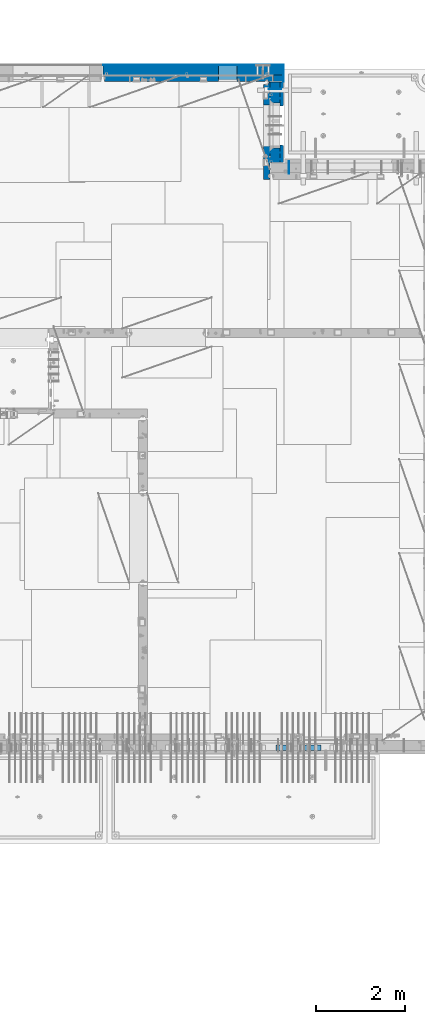
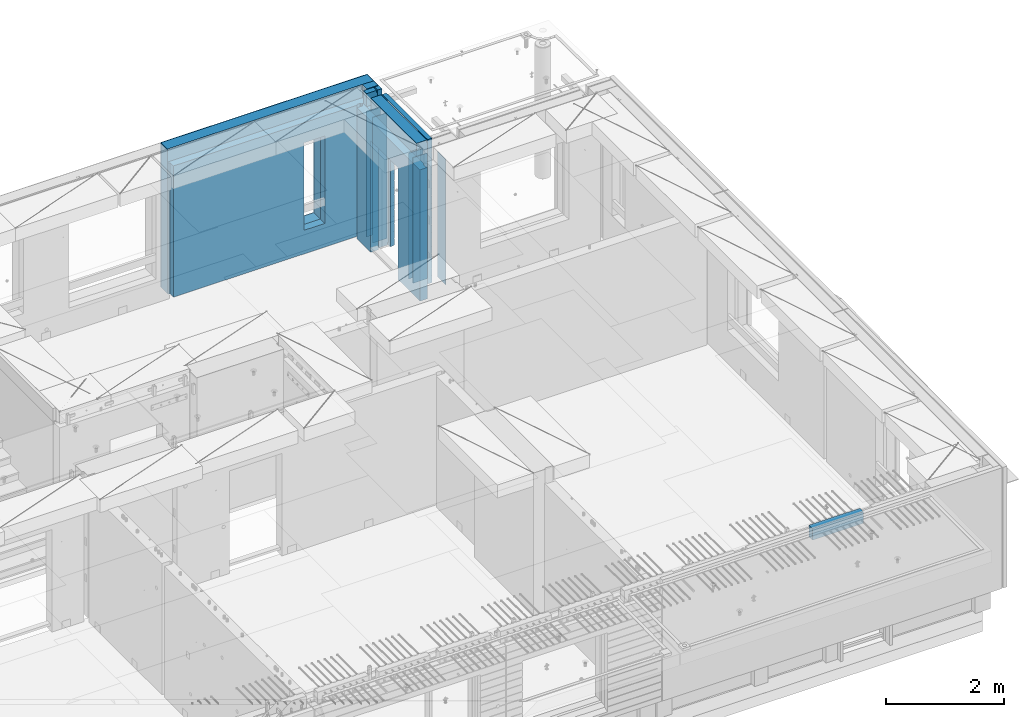
# One storey, part 220 of 325: 14 walls, 5 elements without a shape of their own.
"""IFC2X3 building model written with IfcOpenShell, lengths in millimetres."""

from ifc_helpers import new_model, si_unit, frame, origin_with_axes, place, context, subcontext, project, spatial, faceted_brep, material, type_object, element, aggregate, save


model = new_model("IFC2X3")

# Units and contexts
model_context = context("Model", 3, precision=1e-05, world=origin_with_axes())
body_context = subcontext(model_context, "Body", "Model", "MODEL_VIEW")
ifc_project = project(units=[si_unit("LENGTHUNIT", "METRE", prefix="MILLI"), si_unit("AREAUNIT", "SQUARE_METRE"), si_unit("VOLUMEUNIT", "CUBIC_METRE"), si_unit("MASSUNIT", "GRAM", prefix="KILO"), si_unit("TIMEUNIT", "SECOND"), si_unit("PLANEANGLEUNIT", "RADIAN"), si_unit("SOLIDANGLEUNIT", "STERADIAN"), si_unit("THERMODYNAMICTEMPERATUREUNIT", "DEGREE_CELSIUS"), si_unit("LUMINOUSINTENSITYUNIT", "LUMEN")], contexts=[model_context])

# Site, building, storey
site_placement = place(None, origin_with_axes())
site = spatial("IfcSite", under=ifc_project, at=site_placement, CompositionType="ELEMENT")
building_placement = place(site_placement, origin_with_axes())
building = spatial("IfcBuilding", under=site, at=building_placement, CompositionType="ELEMENT")
storey_placement = place(building_placement, origin_with_axes())
storey = spatial("IfcBuildingStorey", under=building, at=storey_placement, Name="1", CompositionType="ELEMENT", Elevation=0.0)

# Assembly, walls
assembly_1_placement = place(storey_placement, origin_with_axes())
assembly_1 = element("IfcElementAssembly", 1, at=assembly_1_placement, inside=storey, AssemblyPlace="NOTDEFINED", PredefinedType="REINFORCEMENT_UNIT")
ifc_material_1 = material(Name="Undefined")
wall_type_1 = type_object("IfcWallType", PredefinedType="NOTDEFINED")
wall_1_placement = place(assembly_1_placement, frame((31429.9951872276, 20875.0, 83115.0), z_axis=(0.0, 0.0, 1.0), x_axis=(1.0, 0.0, 0.0)))
wall_1 = element("IfcWall", 2, at=wall_1_placement, type_object=wall_type_1, material=ifc_material_1, Name="(PD)", context=body_context, shape_type="Brep", body=[
    faceted_brep([(0.0, 5.0, -1300.0), (0.0, 5.0, 1300.0), (280.0, 5.0, 1300.0), (280.0, 5.0, -1300.0), (0.0, -5.0, 1300.0), (280.0, -5.0, 1300.0), (0.0, -5.0, -1300.0), (280.0, -5.0, -1300.0)], [[[0, 1, 2, 3]], [[1, 4, 5, 2]], [[4, 6, 7, 5]], [[6, 0, 3, 7]], [[5, 7, 3, 2]], [[6, 4, 1, 0]]]),
])
wall_2_placement = place(assembly_1_placement, frame((31429.9951872276, 21025.0, 83115.0), z_axis=(0.0, 0.0, 1.0), x_axis=(1.0, 0.0, 0.0)))
wall_2 = element("IfcWall", 3, at=wall_2_placement, type_object=wall_type_1, material=ifc_material_1, Name="(PD)", context=body_context, shape_type="Brep", body=[
    faceted_brep([(0.0, 5.0, -1300.0), (0.0, 5.0, 1300.0), (280.0, 5.0, 1300.0), (280.0, 5.0, -1300.0), (0.0, -5.0, 1300.0), (280.0, -5.0, 1300.0), (0.0, -5.0, -1300.0), (280.0, -5.0, -1300.0)], [[[0, 1, 2, 3]], [[1, 4, 5, 2]], [[4, 6, 7, 5]], [[6, 0, 3, 7]], [[5, 7, 3, 2]], [[6, 4, 1, 0]]]),
])

# Assembly, wall
assembly_2_placement = place(storey_placement, origin_with_axes())
assembly_2 = element("IfcElementAssembly", 4, at=assembly_2_placement, inside=storey, AssemblyPlace="NOTDEFINED", PredefinedType="REINFORCEMENT_UNIT")
wall_3_placement = place(assembly_2_placement, frame((31890.0, 20549.9951872276, 83115.0), z_axis=(0.0, 0.0, 1.0), x_axis=(0.0, 1.0, 0.0)))
wall_3 = element("IfcWall", 5, at=wall_3_placement, type_object=wall_type_1, material=ifc_material_1, Name="(PD)", context=body_context, shape_type="Brep", body=[
    faceted_brep([(0.0, 5.0, -1300.0), (0.0, 5.0, 1300.0), (280.0, 5.0, 1300.0), (280.0, 5.0, -1300.0), (0.0, -5.0, 1300.0), (280.0, -5.0, 1300.0), (0.0, -5.0, -1300.0), (280.0, -5.0, -1300.0)], [[[0, 1, 2, 3]], [[1, 4, 5, 2]], [[4, 6, 7, 5]], [[6, 0, 3, 7]], [[5, 7, 3, 2]], [[6, 4, 1, 0]]]),
])
aggregate(assembly_2, [wall_3])

# Wall
wall_4_placement = place(assembly_1_placement, frame((31429.9951872276, 22245.0, 83115.0), z_axis=(0.0, 0.0, 1.0), x_axis=(1.0, 0.0, 0.0)))
wall_4 = element("IfcWall", 6, at=wall_4_placement, type_object=wall_type_1, material=ifc_material_1, Name="(PD)", context=body_context, shape_type="Brep", body=[
    faceted_brep([(0.0, 5.0, -1300.0), (0.0, 5.0, 1300.0), (280.0, 5.0, 1300.0), (280.0, 5.0, -1300.0), (0.0, -5.0, 1300.0), (280.0, -5.0, 1300.0), (0.0, -5.0, -1300.0), (280.0, -5.0, -1300.0)], [[[0, 1, 2, 3]], [[1, 4, 5, 2]], [[4, 6, 7, 5]], [[6, 0, 3, 7]], [[5, 7, 3, 2]], [[6, 4, 1, 0]]]),
])

wall_5_placement = place(assembly_1_placement, frame((31429.9951872276, 22454.9997558594, 83115.0), z_axis=(0.0, 0.0, 1.0), x_axis=(1.0, 0.0, 0.0)))
wall_5 = element("IfcWall", 7, at=wall_5_placement, type_object=wall_type_1, material=ifc_material_1, Name="(PD)", context=body_context, shape_type="Brep", body=[
    faceted_brep([(0.0, 5.0, -1300.0), (0.0, 5.0, 1300.0), (280.0, 5.0, 1300.0), (280.0, 5.0, -1300.0), (0.0, -5.0, 1300.0), (280.0, -5.0, 1300.0), (0.0, -5.0, -1300.0), (280.0, -5.0, -1300.0)], [[[0, 1, 2, 3]], [[1, 4, 5, 2]], [[4, 6, 7, 5]], [[6, 0, 3, 7]], [[5, 7, 3, 2]], [[6, 4, 1, 0]]]),
])

# Assemblies, wall
assembly_3_placement = place(storey_placement, origin_with_axes())
assembly_3 = element("IfcElementAssembly", 8, at=assembly_3_placement, inside=storey, AssemblyPlace="NOTDEFINED", PredefinedType="REINFORCEMENT_UNIT")
assembly_4_placement = place(assembly_3_placement, origin_with_axes())
assembly_4 = element("IfcElementAssembly", 9, at=assembly_4_placement, Name="Steel Assembly", AssemblyPlace="NOTDEFINED", PredefinedType="NOTDEFINED")
aggregate(assembly_3, [assembly_4])
ifc_material_2 = material()
wall_type_2 = type_object("IfcWallType", PredefinedType="NOTDEFINED")
wall_6_placement = place(assembly_4_placement, frame((31599.9998568133, 7690.00021946163, 84590.0), z_axis=(0.0, 0.0, 1.0), x_axis=(1.0, 0.0, 0.0)))
wall_6 = element("IfcWall", 10, at=wall_6_placement, type_object=wall_type_2, material=ifc_material_2, context=body_context, shape_type="Brep", body=[
    faceted_brep([(0.0, 60.0, -120.0), (0.0, 60.0, 120.0), (1000.0, 60.0, 120.0), (1000.0, 60.0, -120.0), (0.0, -60.0, 120.0), (1000.0, -60.0, 120.0), (0.0, -60.0, -120.0), (1000.0, -60.0, -120.0)], [[[0, 1, 2, 3]], [[1, 4, 5, 2]], [[4, 6, 7, 5]], [[6, 0, 3, 7]], [[5, 7, 3, 2]], [[6, 4, 1, 0]]]),
])
aggregate(assembly_4, [wall_6])

# Wall
ifc_material_3 = material(Name="COS5gt")
wall_type_3 = type_object("IfcWallType", PredefinedType="NOTDEFINED")
wall_7_placement = place(assembly_1_placement, frame((31569.9951872276, 22605.0, 83247.5), z_axis=(0.0, 0.0, 1.0), x_axis=(0.0, -1.0, 0.0)))
wall_7 = element("IfcWall", 11, at=wall_7_placement, type_object=wall_type_3, material=ifc_material_3, context=body_context, shape_type="Brep", body=[
    faceted_brep([(0.0, 90.0, -1492.5), (0.0, 90.0, -1442.5), (465.000109818619, 90.0, -1442.5), (465.000109818619, 90.0, -1492.5), (0.0, -110.0, -1492.5), (465.000109818619, -110.0, -1492.5), (1800.0, -110.0, 1492.5), (1800.0, 90.0, 1492.5), (255.0, 90.0, 1492.5), (255.0, -110.0, 1492.5), (1800.0, 90.0, -1442.5), (1800.0, 90.0, -1492.5), (1475.00010981862, 90.0, -1492.5), (1475.00010981862, 90.0, -1442.5), (1800.0, 110.0, -1442.5), (1475.00010981862, 110.0, -1442.5), (1800.0, 110.0, 1442.5), (1800.0, 90.0, 1442.5), (1800.0, -110.0, -1492.5), (1475.00010981862, -110.0, -1492.5), (1475.00010981862, -110.000000000004, 857.5), (1475.00010981862, 110.0, 857.5), (465.000109818619, -110.000000000004, 857.5), (465.000109818619, 110.0, 857.5), (255.0, -110.0, 1222.5), (105.0, -110.0, 1222.5), (105.0, -110.0, 1492.5), (0.0, -110.0, 1492.5), (0.0, 90.0, 1492.5), (105.0, 90.0, 1492.5), (0.0, 110.0, 1442.5), (0.0, 90.0, 1442.5), (105.0, 90.0, 1442.5), (105.0, 110.0, 1442.5), (0.0, 110.0, -1442.5), (465.000109818619, 110.0, -1442.5), (105.0, 110.0, 1222.5), (255.0, 110.0, 1222.5), (255.0, 110.0, 1442.5), (255.0, 90.0, 1442.5)], [[[0, 1, 2, 3]], [[4, 0, 3, 5]], [[6, 7, 8, 9]], [[10, 11, 12, 13]], [[14, 10, 13, 15]], [[16, 17, 7, 6, 18, 11, 10, 14]], [[11, 18, 19, 12]], [[15, 13, 12, 19, 20, 21]], [[21, 20, 22, 23]], [[19, 18, 6, 9, 24, 25, 26, 27, 4, 5, 22, 20]], [[28, 27, 26, 29]], [[30, 31, 32, 33]], [[0, 4, 27, 28, 31, 30, 34, 1]], [[1, 34, 35, 2]], [[23, 22, 5, 3, 2, 35]], [[34, 30, 33, 36, 37, 38, 16, 14, 15, 21, 23, 35]], [[17, 16, 38, 39]], [[7, 17, 39, 8]], [[38, 37, 24, 9, 8, 39]], [[36, 25, 24, 37]], [[33, 32, 29, 26, 25, 36]], [[31, 28, 29, 32]]]),
])

# Assembly, walls
assembly_5_placement = place(storey_placement, origin_with_axes())
assembly_5 = element("IfcElementAssembly", 12, at=assembly_5_placement, inside=storey, AssemblyPlace="NOTDEFINED", PredefinedType="REINFORCEMENT_UNIT")
ifc_material_4 = material()
wall_8_placement = place(assembly_5_placement, frame((31645.0, 22620.0, 83247.5), z_axis=(0.0, 0.0, 1.0), x_axis=(0.0, 1.0, 0.0)))
wall_8 = element("IfcWall", 13, at=wall_8_placement, type_object=wall_type_3, material=ifc_material_4, context=body_context, shape_type="Brep", body=[
    faceted_brep([(0.0, 110.0, -1492.5), (0.0, 110.0, 1492.5), (150.0, 110.0, 1492.5), (150.0, 110.0, -1492.5), (0.0, -110.0, 1492.5), (150.0, -110.0, 1492.5), (0.0, -110.0, -1492.5), (150.0, -110.0, -1492.5)], [[[0, 1, 2, 3]], [[1, 4, 5, 2]], [[4, 6, 7, 5]], [[6, 0, 3, 7]], [[5, 7, 3, 2]], [[6, 4, 1, 0]]]),
])
wall_9_placement = place(assembly_5_placement, frame((27720.0, 22880.0, 83247.5), z_axis=(0.0, 0.0, 1.0), x_axis=(1.0, 0.0, 0.0)))
wall_9 = element("IfcWall", 14, at=wall_9_placement, type_object=wall_type_3, material=ifc_material_4, context=body_context, shape_type="Brep", body=[
    faceted_brep([(0.0, -110.0, -1492.5), (0.0, 110.0, -1492.5), (4035.0, 110.0, -1492.5), (4035.0, -110.0, -1492.5), (0.0, -110.0, 1492.5), (0.0, 110.0, 1492.5), (4035.0, -110.0, 1492.5), (4035.0, 110.0, 1492.5), (2584.99948280293, 110.0, -1002.5), (2994.99948280293, 110.0, -1002.5), (2994.99948280293, 110.0, 807.5), (2584.99948280293, 110.0, 807.5), (2584.99948280293, -110.0, -1002.5), (2584.99948280293, -110.0, 807.5), (2994.99948280293, -110.0, 807.5), (2994.99948280293, -110.0, -1002.5)], [[[0, 1, 2, 3]], [[0, 4, 5, 1]], [[5, 4, 6, 7]], [[1, 5, 7, 2], [8, 9, 10, 11]], [[6, 3, 2, 7]], [[4, 0, 3, 6], [12, 13, 14, 15]], [[10, 14, 13, 11]], [[9, 15, 14, 10]], [[8, 12, 15, 9]], [[11, 13, 12, 8]]]),
])

# Wall
ifc_material_5 = material(Name="CONCRETE/C30/37")
wall_type_4 = type_object("IfcWallType", PredefinedType="NOTDEFINED")
wall_10_placement = place(assembly_1_placement, frame((31722.4951872276, 22605.0, 83247.5), z_axis=(0.0, 0.0, 1.0), x_axis=(0.0, -1.0, 0.0)))
wall_10 = element("IfcWall", 15, at=wall_10_placement, type_object=wall_type_4, material=ifc_material_5, context=body_context, shape_type="Brep", body=[
    faceted_brep([(0.0, 32.4999992507037, 744.999999999258), (0.0, 32.4999991127006, 755.00000040044), (526.17471776616, 32.4999991126897, 755.000000400425), (526.174717749924, 32.4999992507001, 744.999999999229), (0.0, 42.5, 742.999999944761), (524.998050995091, 42.4999995462422, 742.999999944761), (0.0, 42.5, 606.999999889245), (524.998050995091, 42.4999994639038, 606.999999889245), (3.63797880709171e-12, 32.4999991127006, 605.00000040044), (526.17471776616, 32.4999991126897, 605.000000400425), (3.63797880709171e-12, 32.4999992507037, 594.999999999258), (526.174717749924, 32.4999992507001, 594.999999999229), (0.0, 42.5, 592.999999944761), (524.998050995091, 42.4999995343132, 592.999999944761), (0.0, 42.5, 456.999999889245), (524.998050995091, 42.4999994639038, 456.999999889245), (0.0, 32.4999991127006, 455.00000040044), (526.17471776616, 32.4999991126897, 455.000000400425), (0.0, 32.4999992507037, 444.999999999258), (526.174717749924, 32.4999992507001, 444.999999999229), (0.0, 42.5, 442.999999944761), (524.998050995091, 42.4999995254038, 442.999999944761), (0.0, 42.5, 306.999999889245), (524.998050995091, 42.4999994639038, 306.999999889245), (-3.63797880709171e-12, 32.4999991127006, 305.00000040044), (526.17471776616, 32.4999991126897, 305.000000400425), (-3.63797880709171e-12, 32.4999992507037, 294.999999999258), (526.174717749924, 32.4999992507001, 294.999999999229), (0.0, 42.5, 292.999999944761), (524.998050995091, 42.499999518499, 292.999999944761), (0.0, 42.5, 156.999999889245), (524.998050995091, 42.4999994639038, 156.999999889245), (-3.63797880709171e-12, 32.4999991127006, 155.00000040044), (526.17471776616, 32.4999991126897, 155.000000400425), (-3.63797880709171e-12, 32.4999992507037, 144.999999999258), (526.174717749924, 32.4999992507001, 144.999999999229), (0.0, 42.5, 142.999999944761), (524.998050995091, 42.4999995129838, 142.999999944761), (0.0, 42.5, 6.99999988924537), (524.998050995091, 42.4999994639038, 6.99999988924537), (0.0, 32.4999991127006, 5.0000004004396), (526.17471776616, 32.4999991126897, 5.00000040042505), (0.0, 32.4999992507037, -5.00000000074215), (526.174717749924, 32.4999992507001, -5.00000000077125), (0.0, 42.5, -7.00000005523907), (524.998050995091, 42.49999950848, -7.00000005523907), (0.0, 42.5, -143.000000110755), (524.998050995091, 42.4999994639038, -143.000000110755), (3.63797880709171e-12, 32.4999991127006, -144.99999959956), (526.17471776616, 32.4999991126897, -144.999999599575), (3.63797880709171e-12, 32.4999992507037, -155.000000000742), (526.174717749924, 32.4999992507001, -155.000000000771), (0.0, 42.5, -157.000000055239), (524.998050995091, 42.4999995047365, -157.000000055239), (0.0, 42.5, -293.000000110755), (524.998050995091, 42.4999994639038, -293.000000110755), (0.0, 32.4999991127006, -294.99999959956), (526.17471776616, 32.4999991126897, -294.999999599575), (0.0, 32.4999992507037, -305.000000000742), (526.174717749924, 32.4999992507001, -305.000000000771), (0.0, 42.5, -307.000000055239), (524.998050995091, 42.4999995015714, -307.000000055239), (0.0, 42.5, -443.000000110755), (524.998050995091, 42.4999994639038, -443.000000110755), (0.0, 32.4999991127006, -444.99999959956), (526.17471776616, 32.4999991126897, -444.999999599575), (0.0, 32.4999992507037, -455.000000000742), (526.174717749924, 32.4999992507001, -455.000000000771), (0.0, 42.5, -457.000000055239), (524.998050995091, 42.4999994988648, -457.000000055239), (0.0, 42.5, -593.000000110755), (524.998050995091, 42.4999994639038, -593.000000110755), (3.63797880709171e-12, 32.4999991127006, -594.99999959956), (526.17471776616, 32.4999991126897, -594.999999599575), (3.63797880709171e-12, 32.4999992507037, -605.000000000742), (526.174717749924, 32.4999992507001, -605.000000000771), (0.0, 42.5, -607.000000055239), (524.998050995091, 42.4999994965183, -607.000000055239), (0.0, 42.5, -743.000000110755), (524.998050995091, 42.4999994639038, -743.000000110755), (0.0, 32.4999991127006, -744.99999959956), (526.17471776616, 32.4999991126897, -744.999999599575), (0.0, 32.4999992507037, -755.000000000742), (526.174717749924, 32.4999992507001, -755.000000000771), (0.0, 42.5, -757.000000055239), (524.998050995091, 42.4999994944665, -757.000000055239), (0.0, 42.5, -893.000000110755), (524.998050995091, 42.4999994639038, -893.000000110755), (0.0, 32.4999991127006, -894.99999959956), (526.17471776616, 32.4999991126897, -894.999999599575), (0.0, 32.4999992507037, -905.000000000742), (526.174717749924, 32.4999992507001, -905.000000000771), (0.0, 42.5, -907.000000055239), (524.998050995091, 42.4999994926584, -907.000000055239), (0.0, 42.5, -1043.00000011075), (524.998050995091, 42.4999994639038, -1043.00000011075), (0.0, 32.4999991127006, -1044.99999959956), (526.17471776616, 32.4999991126897, -1044.99999959957), (0.0, 32.4999992507037, -1055.00000000074), (526.174717749924, 32.4999992507001, -1055.00000000077), (0.0, 42.5, -1057.00000005524), (524.998050995091, 42.499999491054, -1057.00000005524), (0.0, 42.5, -1193.00000011075), (524.998050995091, 42.4999994639038, -1193.00000011075), (0.0, 32.4999991127006, -1194.99999959956), (526.17471776616, 32.4999991126897, -1194.99999959957), (0.0, 32.4999992507037, -1205.00000000074), (526.174717749924, 32.4999992507001, -1205.00000000077), (0.0, 42.5, -1207.00000005524), (524.998050995091, 42.499999489617, -1207.00000005524), (0.0, 42.5, -1343.00000011075), (524.998050995091, 42.4999994639038, -1343.00000011075), (0.0, 32.4999991127006, -1344.99999959956), (526.17471776616, 32.4999991126897, -1344.99999959957), (0.0, 32.4999992507037, -1355.00000000074), (526.174717749924, 32.4999992507001, -1355.00000000077), (0.0, 42.5, -1357.00000005524), (524.998050995091, 42.5, -1357.00000005524), (0.0, 42.5, -1492.5), (524.998050995091, 42.5, -1492.5), (0.0, 42.5, 1356.99999988925), (0.0, 42.5, 1492.5), (105.0, 42.5, 1492.5), (105.0, 42.499999287309, 1356.99999988925), (0.0, -42.5, 1492.5), (105.0, -42.5, 1492.5), (1800.0, 32.4999991126897, 755.000000400425), (1800.0, 32.4999992507001, 744.999999999229), (1413.82138424026, 32.4999992507001, 744.999999999229), (1413.82138422402, 32.4999991126897, 755.000000400425), (1800.0, 42.5, 742.999999944761), (1414.99805099509, 42.4999998629828, 742.999999944761), (1800.0, 42.5, 606.999999889245), (1414.99805099509, 42.4999998381209, 606.999999889245), (1800.0, 32.4999991126897, 605.000000400425), (1413.82138422402, 32.4999991126897, 605.000000400425), (1800.0, 32.4999992507001, 594.999999999229), (1413.82138424026, 32.4999992507001, 594.999999999229), (1800.0, 42.5, 592.999999944761), (1414.99805099509, 42.4999998593812, 592.999999944761), (1800.0, 42.5, 456.999999889245), (1414.99805099509, 42.4999998381209, 456.999999889245), (1800.0, 32.4999991126897, 455.000000400425), (1413.82138422402, 32.4999991126897, 455.000000400425), (1800.0, 32.4999992507001, 444.999999999229), (1413.82138424026, 32.4999992507001, 444.999999999229), (1800.0, 42.5, 442.999999944761), (1414.99805099509, 42.4999998566891, 442.999999944761), (1800.0, 42.5, 306.999999889245), (1414.99805099509, 42.4999998381209, 306.999999889245), (1800.0, 32.4999991126897, 305.000000400425), (1413.82138422402, 32.4999991126897, 305.000000400425), (1800.0, 32.4999992507001, 294.999999999229), (1413.82138424026, 32.4999992507001, 294.999999999229), (1800.0, 42.5, 292.999999944761), (1414.99805099509, 42.4999998546045, 292.999999944761), (1800.0, 42.5, 156.999999889245), (1414.99805099509, 42.4999998381209, 156.999999889245), (1800.0, 32.4999991126897, 155.000000400425), (1413.82138422402, 32.4999991126897, 155.000000400425), (1800.0, 32.4999992507001, 144.999999999229), (1413.82138424026, 32.4999992507001, 144.999999999229), (1800.0, 42.5, 142.999999944761), (1414.99805099509, 42.4999998529383, 142.999999944761), (1800.0, 42.5, 6.99999988924537), (1414.99805099509, 42.4999998381209, 6.99999988924537), (1800.0, 32.4999991126897, 5.00000040042505), (1413.82138422402, 32.4999991126897, 5.00000040042505), (1800.0, 32.4999992507001, -5.00000000077125), (1413.82138424026, 32.4999992507001, -5.00000000077125), (1800.0, 42.5, -7.00000005523907), (1414.99805099509, 42.4999998515814, -7.00000005523907), (1800.0, 42.5, -143.000000110755), (1414.99805099509, 42.4999998381209, -143.000000110755), (1800.0, 32.4999991126897, -144.999999599575), (1413.82138422402, 32.4999991126897, -144.999999599575), (1800.0, 32.4999992507001, -155.000000000771), (1413.82138424026, 32.4999992507001, -155.000000000771), (1800.0, 42.5, -157.000000055239), (1414.99805099509, 42.49999985045, -157.000000055239), (1800.0, 42.5, -293.000000110755), (1414.99805099509, 42.4999998381209, -293.000000110755), (1800.0, 32.4999991126897, -294.999999599575), (1413.82138422402, 32.4999991126897, -294.999999599575), (1800.0, 32.4999992507001, -305.000000000771), (1413.82138424026, 32.4999992507001, -305.000000000771), (1800.0, 42.5, -307.000000055239), (1414.99805099509, 42.4999998494932, -307.000000055239), (1800.0, 42.5, -443.000000110755), (1414.99805099509, 42.4999998381209, -443.000000110755), (1800.0, 32.4999991126897, -444.999999599575), (1413.82138422402, 32.4999991126897, -444.999999599575), (1800.0, 32.4999992507001, -455.000000000771), (1413.82138424026, 32.4999992507001, -455.000000000771), (1800.0, 42.5, -457.000000055239), (1414.99805099509, 42.4999998486746, -457.000000055239), (1800.0, 42.5, -593.000000110755), (1414.99805099509, 42.4999998381209, -593.000000110755), (1800.0, 32.4999991126897, -594.999999599575), (1413.82138422402, 32.4999991126897, -594.999999599575), (1800.0, 32.4999992507001, -605.000000000771), (1413.82138424026, 32.4999992507001, -605.000000000771), (1800.0, 42.5, -607.000000055239), (1414.99805099509, 42.4999998479689, -607.000000055239), (1800.0, 42.5, -743.000000110755), (1414.99805099509, 42.4999998381209, -743.000000110755), (1800.0, 32.4999991126897, -744.999999599575), (1413.82138422402, 32.4999991126897, -744.999999599575), (1800.0, 32.4999992507001, -755.000000000771), (1413.82138424026, 32.4999992507001, -755.000000000771), (1800.0, 42.5, -757.000000055239), (1414.99805099509, 42.4999998473468, -757.000000055239), (1800.0, 42.5, -893.000000110755), (1414.99805099509, 42.4999998381209, -893.000000110755), (1800.0, 32.4999991126897, -894.999999599575), (1413.82138422402, 32.4999991126897, -894.999999599575), (1800.0, 32.4999992507001, -905.000000000771), (1413.82138424026, 32.4999992507001, -905.000000000771), (1800.0, 42.5, -907.000000055239), (1414.99805099509, 42.4999998468011, -907.000000055239), (1800.0, 42.5, -1043.00000011075), (1414.99805099509, 42.4999998381209, -1043.00000011075), (1800.0, 32.4999991126897, -1044.99999959957), (1413.82138422402, 32.4999991126897, -1044.99999959957), (1800.0, 32.4999992507001, -1055.00000000077), (1413.82138424026, 32.4999992507001, -1055.00000000077), (1800.0, 42.5, -1057.00000005524), (1414.99805099509, 42.4999998463172, -1057.00000005524), (1800.0, 42.5, -1193.00000011075), (1414.99805099509, 42.4999998381209, -1193.00000011075), (1800.0, 32.4999991126897, -1194.99999959957), (1413.82138422402, 32.4999991126897, -1194.99999959957), (1800.0, 32.4999992507001, -1205.00000000077), (1413.82138424026, 32.4999992507001, -1205.00000000077), (1800.0, 42.5, -1207.00000005524), (1414.99805099509, 42.4999998458843, -1207.00000005524), (1800.0, 42.5, -1343.00000011075), (1414.99805099509, 42.4999998381209, -1343.00000011075), (1800.0, 32.4999991126897, -1344.99999959957), (1413.82138422402, 32.4999991126897, -1344.99999959957), (1800.0, 32.4999992507001, -1355.00000000077), (1413.82138424026, 32.4999992507001, -1355.00000000077), (1800.0, 42.5, -1357.00000005524), (1414.99805099509, 42.5, -1357.00000005524), (1800.0, 42.5, -1492.5), (1414.99805099509, 42.5, -1492.5), (1800.0, -42.5, -1492.5), (1404.99638432842, -42.5, -1492.5), (1414.99805099509, 42.4999998381209, 756.999999889245), (1404.99638432842, -42.5000000000036, 782.5), (1404.99638432842, -42.5000000000036, 787.502857142856), (1414.99805099509, 42.5, 782.5), (1800.0, 42.5, 756.999999889245), (0.0, 42.5, 892.999999944761), (0.0, 32.4999992507037, 894.999999999258), (1800.0, 32.4999992507001, 894.999999999229), (1800.0, 42.5, 892.999999944761), (0.0, 32.4999991127006, 905.00000040044), (1800.0, 32.4999991126897, 905.000000400425), (0.0, 42.5, 906.999999889245), (1800.0, 42.5, 906.999999889245), (0.0, 42.5, 1042.99999994476), (1800.0, 42.5, 1042.99999994476), (0.0, 32.4999992507037, 1044.99999999926), (1800.0, 32.4999992507001, 1044.99999999923), (0.0, 32.4999991127006, 1055.00000040044), (1800.0, 32.4999991126897, 1055.00000040043), (0.0, 42.5, 1056.99999988925), (1800.0, 42.5, 1056.99999988925), (0.0, 42.5, 1192.99999994476), (1800.0, 42.5, 1192.99999994476), (1800.0, -42.5, 1492.5), (1800.0, 42.5, 1492.5), (255.0, 42.5, 1492.5), (255.0, -42.5, 1492.5), (1800.0, 42.5, 1356.99999988925), (255.0, 42.499999350377, 1356.99999988925), (1800.0, 32.4999991126897, 1355.00000040043), (1800.0, 32.4999992507001, 1344.99999999923), (255.0, 32.4999992507001, 1344.99999999923), (255.0, 32.4999991126897, 1355.00000040043), (1800.0, 42.5, 1342.99999994476), (255.0, 42.4999996598308, 1342.99999994476), (105.0, 42.4999993874699, 1222.5), (105.0, -42.5, 1222.5), (255.0, -42.5, 1222.5), (255.0, 42.4999994355167, 1222.5), (1800.0, 32.4999992507001, 1194.99999999923), (1800.0, 32.4999991126897, 1205.00000040043), (1800.0, 42.5, 1206.99999988925), (0.0, 32.4999992507037, 1194.99999999926), (0.0, 32.4999991127006, 1205.00000040044), (0.0, 42.5, 1206.99999988925), (0.0, 42.5, 1342.99999994476), (105.0, 42.4999996268052, 1342.99999994476), (-3.63797880709171e-12, 32.4999992507037, 1344.99999999926), (105.0, 32.4999992507001, 1344.99999999923), (-3.63797880709171e-12, 32.4999991127006, 1355.00000040044), (105.0, 32.4999991126897, 1355.00000040043), (0.0, 42.5, 756.999999889245), (0.0, -42.5, -1492.5), (534.999717661754, -42.5, -1492.5), (534.999717661758, -42.5000000000036, 782.5), (534.999717661758, -42.5000000000036, 787.502857142856), (535.000109818619, 42.5, 782.5), (1405.00010981862, 42.5, 782.5), (524.998050995091, 42.5, 782.5), (524.998050995091, 42.4999994639038, 756.999999889245)], [[[0, 1, 2, 3]], [[4, 0, 3, 5]], [[6, 4, 5, 7]], [[8, 6, 7, 9]], [[10, 8, 9, 11]], [[12, 10, 11, 13]], [[14, 12, 13, 15]], [[16, 14, 15, 17]], [[18, 16, 17, 19]], [[20, 18, 19, 21]], [[22, 20, 21, 23]], [[24, 22, 23, 25]], [[26, 24, 25, 27]], [[28, 26, 27, 29]], [[30, 28, 29, 31]], [[32, 30, 31, 33]], [[34, 32, 33, 35]], [[36, 34, 35, 37]], [[38, 36, 37, 39]], [[40, 38, 39, 41]], [[42, 40, 41, 43]], [[44, 42, 43, 45]], [[46, 44, 45, 47]], [[48, 46, 47, 49]], [[50, 48, 49, 51]], [[52, 50, 51, 53]], [[54, 52, 53, 55]], [[56, 54, 55, 57]], [[58, 56, 57, 59]], [[60, 58, 59, 61]], [[62, 60, 61, 63]], [[64, 62, 63, 65]], [[66, 64, 65, 67]], [[68, 66, 67, 69]], [[70, 68, 69, 71]], [[72, 70, 71, 73]], [[74, 72, 73, 75]], [[76, 74, 75, 77]], [[78, 76, 77, 79]], [[80, 78, 79, 81]], [[82, 80, 81, 83]], [[84, 82, 83, 85]], [[86, 84, 85, 87]], [[88, 86, 87, 89]], [[90, 88, 89, 91]], [[92, 90, 91, 93]], [[94, 92, 93, 95]], [[96, 94, 95, 97]], [[98, 96, 97, 99]], [[100, 98, 99, 101]], [[102, 100, 101, 103]], [[104, 102, 103, 105]], [[106, 104, 105, 107]], [[108, 106, 107, 109]], [[110, 108, 109, 111]], [[112, 110, 111, 113]], [[114, 112, 113, 115]], [[116, 114, 115, 117]], [[118, 116, 117, 119]], [[120, 121, 122, 123]], [[121, 124, 125, 122]], [[126, 127, 128, 129]], [[127, 130, 131, 128]], [[130, 132, 133, 131]], [[132, 134, 135, 133]], [[134, 136, 137, 135]], [[136, 138, 139, 137]], [[138, 140, 141, 139]], [[140, 142, 143, 141]], [[142, 144, 145, 143]], [[144, 146, 147, 145]], [[146, 148, 149, 147]], [[148, 150, 151, 149]], [[150, 152, 153, 151]], [[152, 154, 155, 153]], [[154, 156, 157, 155]], [[156, 158, 159, 157]], [[158, 160, 161, 159]], [[160, 162, 163, 161]], [[162, 164, 165, 163]], [[164, 166, 167, 165]], [[166, 168, 169, 167]], [[168, 170, 171, 169]], [[170, 172, 173, 171]], [[172, 174, 175, 173]], [[174, 176, 177, 175]], [[176, 178, 179, 177]], [[178, 180, 181, 179]], [[180, 182, 183, 181]], [[182, 184, 185, 183]], [[184, 186, 187, 185]], [[186, 188, 189, 187]], [[188, 190, 191, 189]], [[190, 192, 193, 191]], [[192, 194, 195, 193]], [[194, 196, 197, 195]], [[196, 198, 199, 197]], [[198, 200, 201, 199]], [[200, 202, 203, 201]], [[202, 204, 205, 203]], [[204, 206, 207, 205]], [[206, 208, 209, 207]], [[208, 210, 211, 209]], [[210, 212, 213, 211]], [[212, 214, 215, 213]], [[214, 216, 217, 215]], [[216, 218, 219, 217]], [[218, 220, 221, 219]], [[220, 222, 223, 221]], [[222, 224, 225, 223]], [[224, 226, 227, 225]], [[226, 228, 229, 227]], [[228, 230, 231, 229]], [[230, 232, 233, 231]], [[232, 234, 235, 233]], [[234, 236, 237, 235]], [[236, 238, 239, 237]], [[238, 240, 241, 239]], [[240, 242, 243, 241]], [[242, 244, 245, 243]], [[244, 246, 247, 245]], [[248, 129, 128, 131, 133, 135, 137, 139, 141, 143, 145, 147, 149, 151, 153, 155, 157, 159, 161, 163, 165, 167, 169, 171, 173, 175, 177, 179, 181, 183, 185, 187, 189, 191, 193, 195, 197, 199, 201, 203, 205, 207, 209, 211, 213, 215, 217, 219, 221, 223, 225, 227, 229, 231, 233, 235, 237, 239, 241, 243, 245, 247, 249, 250, 251]], [[252, 126, 129, 248]], [[253, 254, 255, 256]], [[257, 258, 255, 254]], [[259, 260, 258, 257]], [[260, 259, 261, 262]], [[261, 263, 264, 262]], [[265, 266, 264, 263]], [[267, 268, 266, 265]], [[268, 267, 269, 270]], [[271, 272, 273, 274]], [[272, 275, 276, 273]], [[277, 278, 279, 280]], [[278, 281, 282, 279]], [[283, 284, 285, 286]], [[273, 276, 280, 279, 282, 286, 285, 274]], [[275, 277, 280, 276]], [[272, 271, 246, 244, 242, 240, 238, 236, 234, 232, 230, 228, 226, 224, 222, 220, 218, 216, 214, 212, 210, 208, 206, 204, 202, 200, 198, 196, 194, 192, 190, 188, 186, 184, 182, 180, 178, 176, 174, 172, 170, 168, 166, 164, 162, 160, 158, 156, 154, 152, 150, 148, 146, 144, 142, 140, 138, 136, 134, 132, 130, 127, 126, 252, 256, 255, 258, 260, 262, 264, 266, 268, 270, 287, 288, 289, 281, 278, 277, 275]], [[269, 290, 287, 270]], [[291, 288, 287, 290]], [[292, 289, 288, 291]], [[286, 282, 281, 289, 292, 293, 294, 283]], [[293, 295, 296, 294]], [[295, 297, 298, 296]], [[122, 125, 284, 283, 294, 296, 298, 123]], [[297, 120, 123, 298]], [[295, 293, 292, 291, 290, 269, 267, 265, 263, 261, 259, 257, 254, 253, 299, 1, 0, 4, 6, 8, 10, 12, 14, 16, 18, 20, 22, 24, 26, 28, 30, 32, 34, 36, 38, 40, 42, 44, 46, 48, 50, 52, 54, 56, 58, 60, 62, 64, 66, 68, 70, 72, 74, 76, 78, 80, 82, 84, 86, 88, 90, 92, 94, 96, 98, 100, 102, 104, 106, 108, 110, 112, 114, 116, 118, 300, 124, 121, 120, 297]], [[249, 247, 246, 271, 274, 285, 284, 125, 124, 300, 301, 302, 303, 250]], [[304, 305, 251, 250, 303, 306]], [[299, 253, 256, 252, 248, 251, 305, 304, 306, 307]], [[1, 299, 307, 2]], [[306, 303, 302, 301, 119, 117, 115, 113, 111, 109, 107, 105, 103, 101, 99, 97, 95, 93, 91, 89, 87, 85, 83, 81, 79, 77, 75, 73, 71, 69, 67, 65, 63, 61, 59, 57, 55, 53, 51, 49, 47, 45, 43, 41, 39, 37, 35, 33, 31, 29, 27, 25, 23, 21, 19, 17, 15, 13, 11, 9, 7, 5, 3, 2, 307]], [[300, 118, 119, 301]]]),
])

ifc_material_6 = material(Name="CONCRETE/C25/30")
wall_type_5 = type_object("IfcWallType", PredefinedType="NOTDEFINED")
wall_11_placement = place(assembly_1_placement, frame((31384.9951872276, 22620.0, 83112.5), z_axis=(0.0, 0.0, 1.0), x_axis=(0.0, -1.0, 0.0)))
wall_11 = element("IfcWall", 16, at=wall_11_placement, type_object=wall_type_5, material=ifc_material_6, context=body_context, shape_type="Brep", body=[
    faceted_brep([(2190.00481277244, -75.0, 1357.5), (2190.00481277244, -75.0, -1357.5), (2190.00481277244, 75.0, -1357.5), (2190.00481277244, 75.0, 1357.5), (2168.00481277244, 75.0, -1357.5), (2168.00481277244, 75.0, 1357.5), (2155.00481277244, 55.0, -1357.5), (2155.00481277244, 55.0, 1357.5), (2075.00481277244, 55.0, -1357.5), (2075.00481277244, 55.0, 1357.5), (2062.00481277244, 75.0, 1357.5), (2062.00481277244, 75.0, -1357.5), (15.0, 75.0, 1357.5), (15.0, 53.6666666666642, 1357.5), (65.0, 32.0, 1357.5), (65.0, -75.0, 1357.5), (15.0, 75.0, -1357.5), (15.0, 53.6666666666642, -1357.5), (65.0, 32.0, -1357.5), (65.0, -75.0, -1357.5), (1450.00010981862, -75.0, -1357.5), (520.000109818619, -75.0, -1357.5), (520.000109818619, -75.0, 952.5), (1450.00010981862, -75.0, 952.5), (1446.15395597246, 75.0, -1357.5), (1446.15395597247, 75.0, 948.653846153844), (523.846263664771, 75.0, 948.653846153844), (523.846263664771, 75.0, -1357.5)], [[[0, 1, 2, 3]], [[3, 2, 4, 5]], [[5, 4, 6, 7]], [[7, 6, 8, 9]], [[10, 9, 8, 11]], [[12, 13, 14, 15, 0, 3, 5, 7, 9, 10]], [[12, 16, 17, 13]], [[13, 17, 18, 14]], [[14, 18, 19, 15]], [[20, 1, 0, 15, 19, 21, 22, 23]], [[11, 8, 6, 4, 2, 1, 20, 24]], [[16, 12, 10, 11, 24, 25, 26, 27]], [[19, 18, 17, 16, 27, 21]], [[26, 22, 21, 27]], [[25, 23, 22, 26]], [[24, 20, 23, 25]]]),
])

aggregate(assembly_1, [wall_1, wall_2, wall_4, wall_5, wall_10, wall_7, wall_11])

wall_12_placement = place(assembly_5_placement, frame((27720.0, 22695.0, 83112.5), z_axis=(0.0, 0.0, 1.0), x_axis=(1.0, 0.0, 0.0)))
wall_12 = element("IfcWall", 17, at=wall_12_placement, type_object=wall_type_5, material=ifc_material_6, context=body_context, shape_type="Brep", body=[
    faceted_brep([(2584.99948280293, 75.0, 942.5), (2584.99948280293, -75.0, 942.5), (2584.99948280293, -75.0, -867.5), (2584.99948280293, 75.0, -867.5), (2994.99948280293, -75.0, -867.5), (2994.99948280293, 75.0, -867.5), (2994.99948280293, -75.0, 942.5), (2994.99948280293, 75.0, 942.5), (3815.0, -75.0, 1357.5), (3815.0, -75.0, -1357.5), (3815.0, 75.0, -1357.5), (3815.0, 75.0, 1357.5), (0.0, 75.0, -1357.5), (0.0, 75.0, 1357.5), (0.0, 45.0, -1357.5), (0.0, 45.0, 1357.5), (29.9999989126591, 32.0000004547946, -1357.5), (29.9999989126591, 32.0000004547946, 1357.5), (30.0000016637459, -75.0, -1357.5), (30.0000016637459, -75.0, 1357.5), (3624.99518722756, -75.0, 1357.5), (3637.99518722756, -55.0, 1357.5), (3691.99518722756, -55.0, 1357.5), (3704.99518722756, -75.0, 1357.5), (3704.99518722756, -75.0, -1357.5), (3637.99518722756, -55.0, -1357.5), (3624.99518722756, -75.0, -1357.5), (3691.99518722756, -55.0, -1357.5)], [[[0, 1, 2, 3]], [[3, 2, 4, 5]], [[5, 4, 6, 7]], [[7, 6, 1, 0]], [[8, 9, 10, 11]], [[12, 13, 11, 10], [3, 5, 7, 0]], [[13, 12, 14, 15]], [[15, 14, 16, 17]], [[17, 16, 18, 19]], [[8, 11, 13, 15, 17, 19, 20, 21, 22, 23]], [[9, 8, 23, 24]], [[25, 26, 18, 16, 14, 12, 10, 9, 24, 27]], [[23, 22, 27, 24]], [[21, 25, 27, 22]], [[20, 26, 25, 21]], [[19, 18, 26, 20], [2, 1, 6, 4]]]),
])

wall_type_6 = type_object("IfcWallType", PredefinedType="NOTDEFINED")
wall_13_placement = place(assembly_5_placement, frame((31760.0001313636, 22620.0, 83247.5), z_axis=(0.0, 0.0, 1.0), x_axis=(0.0, 1.0, 0.0)))
wall_13 = element("IfcWall", 18, at=wall_13_placement, type_object=wall_type_6, material=ifc_material_5, context=body_context, shape_type="Brep", body=[
    faceted_brep([(0.0, 5.0, -1492.5), (0.0, 5.0, 1492.5), (370.0, 5.0, 1492.5), (370.0, 5.0, -1492.5), (0.0, -5.0, 1492.5), (370.0, -5.0, 1492.5), (0.0, -5.0, -1492.5), (370.0, -5.0, -1492.5)], [[[0, 1, 2, 3]], [[1, 4, 5, 2]], [[4, 6, 7, 5]], [[6, 0, 3, 7]], [[5, 7, 3, 2]], [[6, 4, 1, 0]]]),
])

wall_14_placement = place(assembly_5_placement, frame((27720.0, 22995.0, 83247.5), z_axis=(0.0, 0.0, 1.0), x_axis=(1.0, 0.0, 0.0)))
wall_14 = element("IfcWall", 19, at=wall_14_placement, type_object=wall_type_6, material=ifc_material_5, context=body_context, shape_type="Brep", body=[
    faceted_brep([(0.0, -5.0, -1492.5), (0.0, 5.0, -1492.5), (4045.0, 5.0, -1492.5), (4045.0, -5.0, -1492.5), (0.0, -5.0, 1492.5), (0.0, 5.0, 1492.5), (4045.0, -5.0, 1492.5), (4045.0, 5.0, 1492.5), (2584.99948280293, 5.0, -1002.5), (2994.99948280293, 5.0, -1002.5), (2994.99948280293, 5.0, 807.5), (2584.99948280293, 5.0, 807.5), (2584.99948280293, -5.0, -1002.5), (2584.99948280293, -5.0, 807.5), (2994.99948280293, -5.0, 807.5), (2994.99948280293, -5.0, -1002.5)], [[[0, 1, 2, 3]], [[0, 4, 5, 1]], [[5, 4, 6, 7]], [[1, 5, 7, 2], [8, 9, 10, 11]], [[6, 3, 2, 7]], [[4, 0, 3, 6], [12, 13, 14, 15]], [[10, 14, 13, 11]], [[9, 15, 14, 10]], [[8, 12, 15, 9]], [[11, 13, 12, 8]]]),
])

aggregate(assembly_5, [wall_13, wall_8, wall_14, wall_9, wall_12])

save(model, "model.ifc")
